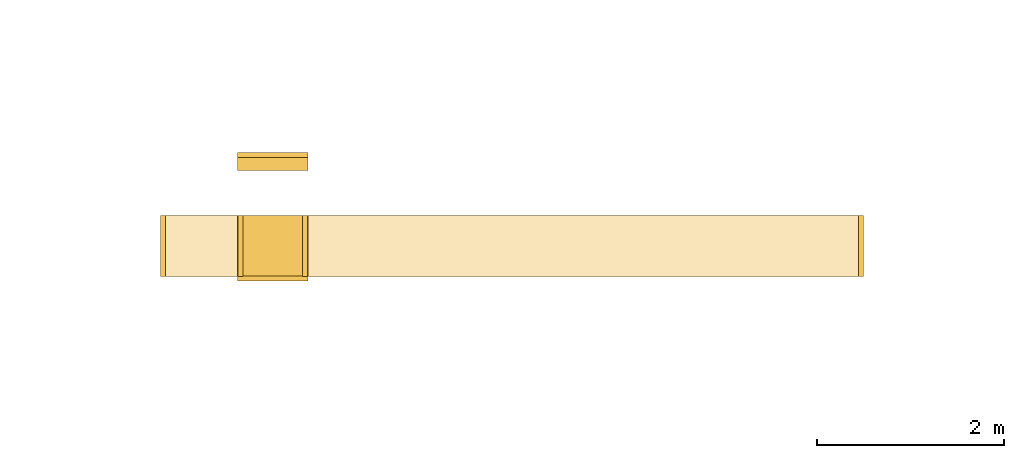
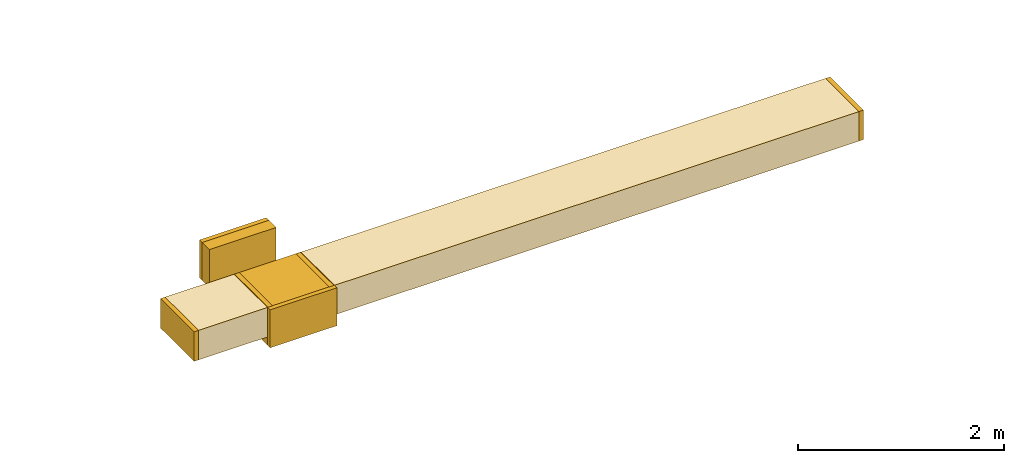
# One storey, part 1 of 9: 10 coverings.
"""IFC2X3 building model written with IfcOpenShell, lengths in millimetres."""

from ifc_helpers import new_model, entity, si_unit, converted_unit, derived_unit, direction, frame, origin, origin_2d_with_axis, place, context, subcontext, project, spatial, rectangle, extrude, element, save


model = new_model("IFC2X3")

# Units and contexts
model_context = context("Model", 3, precision=0.01, world=origin(), true_north=direction((6.12303176911189e-17, 1.0)))
body_context = subcontext(model_context, "Body", "Model", "MODEL_VIEW")
ifc_project = project(units=[si_unit("LENGTHUNIT", "METRE", prefix="MILLI"), si_unit("AREAUNIT", "SQUARE_METRE"), si_unit("VOLUMEUNIT", "CUBIC_METRE"), converted_unit("PLANEANGLEUNIT", "DEGREE", entity("IfcRatioMeasure", 0.0174532925199433), si_unit("PLANEANGLEUNIT", "RADIAN"), dimensions=[0, 0, 0, 0, 0, 0, 0]), si_unit("MASSUNIT", "GRAM", prefix="KILO"), derived_unit("MASSDENSITYUNIT", [(si_unit("MASSUNIT", "GRAM", prefix="KILO"), 1), (si_unit("LENGTHUNIT", "METRE"), -3)]), derived_unit("MOMENTOFINERTIAUNIT", [(si_unit("LENGTHUNIT", "METRE"), 4)]), si_unit("TIMEUNIT", "SECOND"), si_unit("FREQUENCYUNIT", "HERTZ"), si_unit("THERMODYNAMICTEMPERATUREUNIT", "DEGREE_CELSIUS"), derived_unit("THERMALTRANSMITTANCEUNIT", [(si_unit("MASSUNIT", "GRAM", prefix="KILO"), 1), (si_unit("THERMODYNAMICTEMPERATUREUNIT", "KELVIN"), -1), (si_unit("TIMEUNIT", "SECOND"), -3)]), derived_unit("VOLUMETRICFLOWRATEUNIT", [(si_unit("LENGTHUNIT", "METRE"), 3), (si_unit("TIMEUNIT", "SECOND"), -1)]), derived_unit("MASSFLOWRATEUNIT", [(si_unit("MASSUNIT", "GRAM", prefix="KILO"), 1), (si_unit("TIMEUNIT", "SECOND"), -1)]), derived_unit("ROTATIONALFREQUENCYUNIT", [(si_unit("TIMEUNIT", "SECOND"), -1)]), si_unit("ELECTRICCURRENTUNIT", "AMPERE"), si_unit("ELECTRICVOLTAGEUNIT", "VOLT"), si_unit("POWERUNIT", "WATT"), si_unit("FORCEUNIT", "NEWTON", prefix="KILO"), si_unit("ILLUMINANCEUNIT", "LUX"), si_unit("LUMINOUSFLUXUNIT", "LUMEN"), si_unit("LUMINOUSINTENSITYUNIT", "CANDELA"), derived_unit("USERDEFINED", [(si_unit("MASSUNIT", "GRAM", prefix="KILO"), -1), (si_unit("LENGTHUNIT", "METRE"), -2), (si_unit("TIMEUNIT", "SECOND"), 3), (si_unit("LUMINOUSFLUXUNIT", "LUMEN"), 1)]), derived_unit("LINEARVELOCITYUNIT", [(si_unit("LENGTHUNIT", "METRE"), 1), (si_unit("TIMEUNIT", "SECOND"), -1)]), si_unit("PRESSUREUNIT", "PASCAL"), derived_unit("USERDEFINED", [(si_unit("LENGTHUNIT", "METRE"), -2), (si_unit("MASSUNIT", "GRAM", prefix="KILO"), 1), (si_unit("TIMEUNIT", "SECOND"), -2)]), derived_unit("LINEARFORCEUNIT", [(si_unit("MASSUNIT", "GRAM", prefix="KILO"), 1), (si_unit("LENGTHUNIT", "METRE"), 1), (si_unit("TIMEUNIT", "SECOND"), -2), (si_unit("LENGTHUNIT", "METRE"), -1)]), derived_unit("PLANARFORCEUNIT", [(si_unit("MASSUNIT", "GRAM", prefix="KILO"), 1), (si_unit("LENGTHUNIT", "METRE"), 1), (si_unit("TIMEUNIT", "SECOND"), -2), (si_unit("LENGTHUNIT", "METRE"), -2)])], contexts=[model_context])

# Site, building, storey
site_placement = place(None, origin())
site = spatial("IfcSite", under=ifc_project, at=site_placement, CompositionType="ELEMENT")
building_placement = place(site_placement, origin())
building = spatial("IfcBuilding", under=site, at=building_placement, CompositionType="ELEMENT")
storey_placement = place(building_placement, frame((0.0, 0.0, 24000.0)))
storey = spatial("IfcBuildingStorey", under=building, at=storey_placement, CompositionType="ELEMENT", Elevation=24000.0)

# Coverings
covering_1_placement = place(storey_placement, frame((41005.98, 9294.58, 2575.0)))
element("IfcCovering", 1, at=covering_1_placement, inside=storey, PredefinedType="INSULATION", context=body_context, shape_type="SweptSolid", body=[
    extrude(rectangle(XDim=49.9999999999973, YDim=650.0, at=origin_2d_with_axis()), frame((25.0, 325.0, 0.0)), (0.0, 0.0, 1.0), 349.999999999998),
])
covering_2_placement = place(storey_placement, frame((41055.98, 9294.58, 2575.0)))
element("IfcCovering", 2, at=covering_2_placement, inside=storey, PredefinedType="INSULATION", context=body_context, shape_type="SweptSolid", body=[
    extrude(rectangle(XDim=778.881621530124, YDim=650.000000000001, at=origin_2d_with_axis()), frame((389.44, 325.0, 0.0)), (0.0, 0.0, 1.0), 349.999999999998),
])
covering_3_placement = place(storey_placement, frame((42574.87, 9294.58, 2575.0)))
element("IfcCovering", 3, at=covering_3_placement, inside=storey, PredefinedType="INSULATION", context=body_context, shape_type="SweptSolid", body=[
    extrude(rectangle(XDim=5885.0094274255, YDim=650.000000000001, at=origin_2d_with_axis()), frame((2942.5, 325.0, 0.0), z_axis=(0.0, 0.0, 1.0), x_axis=(-1.0, 0.0, 0.0)), (0.0, 0.0, 1.0), 349.999999999998),
])
covering_4_placement = place(storey_placement, frame((48459.87, 9294.58, 2575.0)))
element("IfcCovering", 4, at=covering_4_placement, inside=storey, PredefinedType="INSULATION", context=body_context, shape_type="SweptSolid", body=[
    extrude(rectangle(XDim=49.9999999999973, YDim=650.000000000001, at=origin_2d_with_axis()), frame((25.0, 325.0, 0.0), z_axis=(0.0, 0.0, 1.0), x_axis=(-1.0, 0.0, 0.0)), (0.0, 0.0, 1.0), 349.999999999998),
])
covering_5_placement = place(storey_placement, frame((41829.87, 10425.5, 2475.0)))
element("IfcCovering", 5, at=covering_5_placement, inside=storey, PredefinedType="INSULATION", context=body_context, shape_type="SweptSolid", body=[
    extrude(rectangle(XDim=139.488841597194, YDim=750.000000000003, at=origin_2d_with_axis()), frame((375.0, 69.74, 0.0), z_axis=(0.0, 0.0, 1.0), x_axis=(0.0, 1.0, 0.0)), (0.0, 0.0, 1.0), 450.000000000002),
])
covering_6_placement = place(storey_placement, frame((41829.87, 9247.2, 2475.0)))
element("IfcCovering", 6, at=covering_6_placement, inside=storey, PredefinedType="INSULATION", context=body_context, shape_type="SweptSolid", body=[
    extrude(rectangle(XDim=50.0000000000016, YDim=750.000000000003, at=origin_2d_with_axis()), frame((375.0, 25.0, 0.0), z_axis=(0.0, 0.0, 1.0), x_axis=(0.0, 1.0, 0.0)), (0.0, 0.0, 1.0), 450.000000000002),
])
covering_7_placement = place(storey_placement, frame((41829.87, 10564.99, 2475.0)))
element("IfcCovering", 7, at=covering_7_placement, inside=storey, PredefinedType="INSULATION", context=body_context, shape_type="SweptSolid", body=[
    extrude(rectangle(XDim=750.000000000003, YDim=51.0960000000016, at=origin_2d_with_axis()), frame((375.0, 25.55, 0.0)), (0.0, 0.0, 1.0), 450.000000000002),
])
covering_8_placement = place(storey_placement, frame((41829.87, 9297.2, 2475.0)))
element("IfcCovering", 8, at=covering_8_placement, inside=storey, PredefinedType="INSULATION", context=body_context, shape_type="SweptSolid", body=[
    extrude(rectangle(XDim=648.296900313849, YDim=750.000000000003, at=origin_2d_with_axis()), frame((375.0, 324.15, 0.0), z_axis=(0.0, 0.0, 1.0), x_axis=(0.0, 1.0, 0.0)), (0.0, 0.0, 1.0), 450.000000000002),
])
covering_9_placement = place(storey_placement, frame((42523.77, 9294.58, 2575.0)))
element("IfcCovering", 9, at=covering_9_placement, inside=storey, PredefinedType="INSULATION", context=body_context, shape_type="SweptSolid", body=[
    extrude(rectangle(XDim=51.0960000000449, YDim=650.000000000001, at=origin_2d_with_axis()), frame((25.55, 325.0, 0.0), z_axis=(0.0, 0.0, 1.0), x_axis=(-1.0, 0.0, 0.0)), (0.0, 0.0, 1.0), 349.999999999998),
])
covering_10_placement = place(storey_placement, frame((41834.87, 9294.58, 2575.0)))
element("IfcCovering", 10, at=covering_10_placement, inside=storey, PredefinedType="INSULATION", context=body_context, shape_type="SweptSolid", body=[
    extrude(rectangle(XDim=650.000000000001, YDim=51.0960000000275, at=origin_2d_with_axis()), frame((25.55, 325.0, 0.0), z_axis=(0.0, 0.0, 1.0), x_axis=(0.0, -1.0, 0.0)), (0.0, 0.0, 1.0), 349.999999999998),
])

save(model, "model.ifc")
